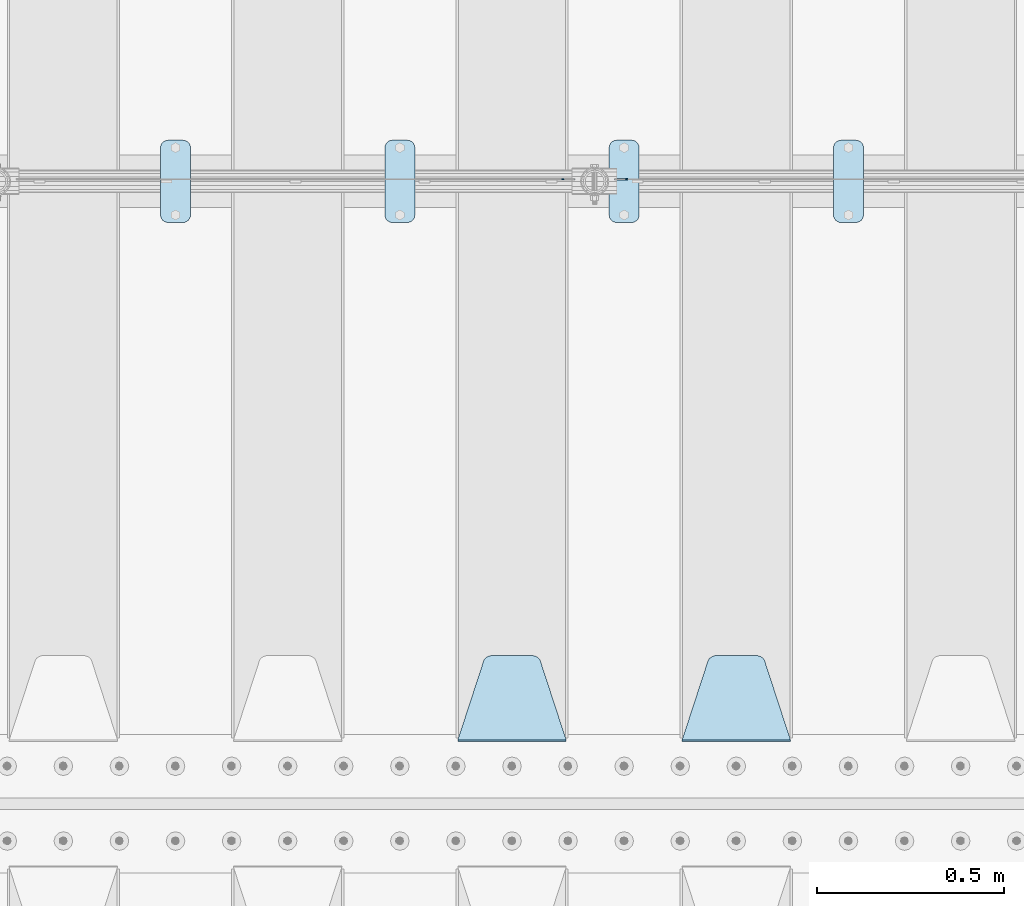
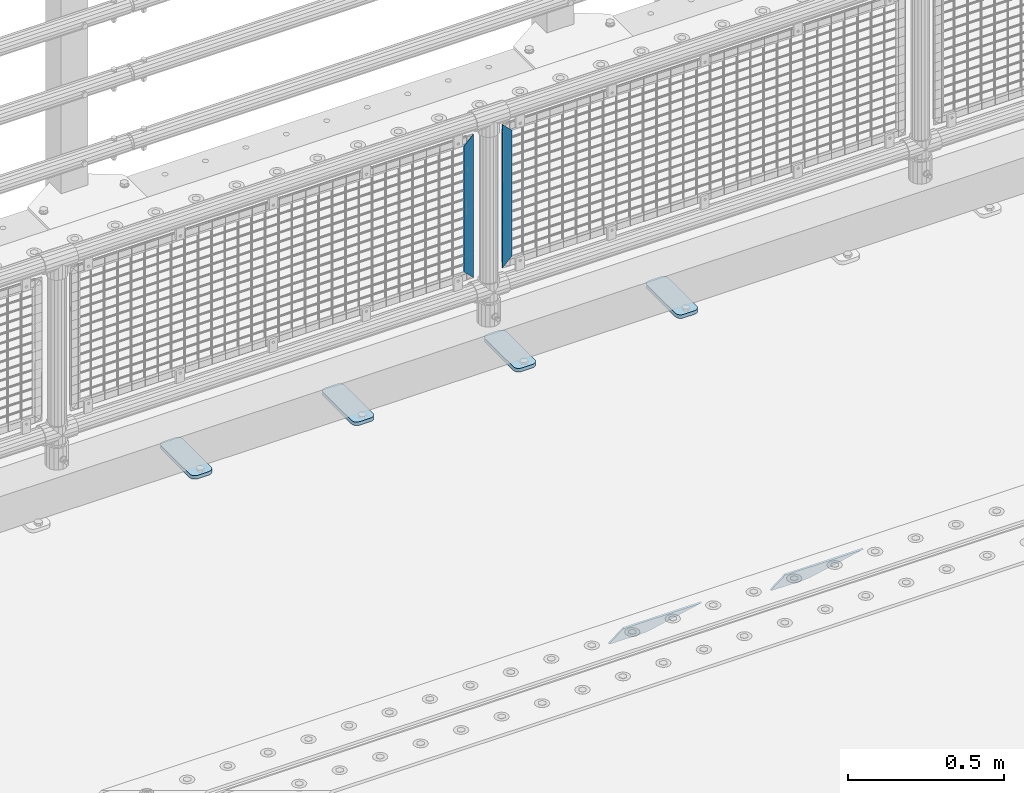
# One storey, part 182 of 208: 8 plates.
"""IFC2X3 building model written with IfcOpenShell, lengths in millimetres."""

from ifc_helpers import new_model, si_unit, frame, origin_with_axes, place, context, subcontext, project, spatial, faceted_brep, material, type_object, element, save


model = new_model("IFC2X3")

# Units and contexts
model_context = context("Model", 3, precision=1e-05, world=origin_with_axes())
body_context = subcontext(model_context, "Body", "Model", "MODEL_VIEW")
ifc_project = project(units=[si_unit("LENGTHUNIT", "METRE", prefix="MILLI"), si_unit("AREAUNIT", "SQUARE_METRE"), si_unit("VOLUMEUNIT", "CUBIC_METRE"), si_unit("MASSUNIT", "GRAM", prefix="KILO"), si_unit("TIMEUNIT", "SECOND"), si_unit("PLANEANGLEUNIT", "RADIAN"), si_unit("SOLIDANGLEUNIT", "STERADIAN"), si_unit("THERMODYNAMICTEMPERATUREUNIT", "DEGREE_CELSIUS"), si_unit("LUMINOUSINTENSITYUNIT", "LUMEN")], contexts=[model_context])

# Site, building, storey
site_placement = place(None, origin_with_axes())
site = spatial("IfcSite", under=ifc_project, at=site_placement, CompositionType="ELEMENT")
building_placement = place(site_placement, origin_with_axes())
building = spatial("IfcBuilding", under=site, at=building_placement, Name="Standard", CompositionType="ELEMENT")
storey_placement = place(building_placement, origin_with_axes())
storey = spatial("IfcBuildingStorey", under=building, at=storey_placement, Name="Undefined", CompositionType="ELEMENT", Elevation=0.0)

# Plates
ifc_material_1 = material(Name="STEEL/S355J2")
plate_type_1 = type_object("IfcPlateType", PredefinedType="NOTDEFINED")
plate_1_placement = place(storey_placement, frame((-31590.0, 4774.5, 21.0199999999977), z_axis=(1.0, 0.0, 0.0), x_axis=(0.0, -1.0, 0.0)))
element("IfcPlate", 1, at=plate_1_placement, inside=storey, type_object=plate_type_1, material=ifc_material_1, context=body_context, shape_type="Brep", body=[
    faceted_brep([(0.0, -7.0, 20.0), (0.0, -7.0, 60.0), (0.0, 7.0, 60.0), (0.0, 7.0, 20.0), (0.384294391935327, -7.0, 63.9018064403208), (0.384294391935327, 7.0, 63.9018064403208), (1.52240934977453, -7.0, 67.6536686473009), (1.52240934977453, 7.0, 67.6536686473009), (3.37060775394912, -7.0, 71.1114046603907), (3.37060775394912, 7.0, 71.1114046603907), (5.85786437626939, -7.0, 74.1421356237297), (5.85786437626939, 7.0, 74.1421356237297), (8.8885953396084, -7.0, 76.62939224605), (8.8885953396084, 7.0, 76.62939224605), (12.3463313526981, -7.0, 78.4775906502255), (12.3463313526981, 7.0, 78.4775906502255), (16.0981935596774, -7.0, 79.6157056080629), (16.0981935596774, 7.0, 79.6157056080629), (20.0, -7.0, 80.0), (20.0, 7.0, 80.0), (200.0, -7.0, 80.0), (200.0, 7.0, 80.0), (203.901806440323, -7.0, 79.6157056080629), (203.901806440323, 7.0, 79.6157056080629), (207.653668647302, -7.0, 78.4775906502255), (207.653668647302, 7.0, 78.4775906502255), (211.111404660393, -7.0, 76.62939224605), (211.111404660393, 7.0, 76.62939224605), (214.142135623731, -7.0, 74.1421356237297), (214.142135623731, 7.0, 74.1421356237297), (216.629392246051, -7.0, 71.1114046603907), (216.629392246051, 7.0, 71.1114046603907), (218.477590650225, -7.0, 67.6536686473009), (218.477590650225, 7.0, 67.6536686473009), (219.615705608065, -7.0, 63.9018064403208), (219.615705608065, 7.0, 63.9018064403208), (220.0, -7.0, 60.0), (220.0, 7.0, 60.0), (220.0, -7.0, 20.0), (220.0, 7.0, 20.0), (219.615705608065, -7.0, 16.0981935596792), (219.615705608065, 7.0, 16.0981935596792), (218.477590650225, -7.0, 12.3463313526991), (218.477590650225, 7.0, 12.3463313526991), (216.629392246051, -7.0, 8.88859533960931), (216.629392246051, 7.0, 8.88859533960931), (214.142135623731, -7.0, 5.8578643762703), (214.142135623731, 7.0, 5.8578643762703), (211.111404660393, -7.0, 3.37060775395003), (211.111404660393, 7.0, 3.37060775395003), (207.653668647302, -7.0, 1.52240934977453), (207.653668647302, 7.0, 1.52240934977453), (203.901806440323, -7.0, 0.384294391937146), (203.901806440323, 7.0, 0.384294391937146), (200.0, -7.0, 0.0), (200.0, 7.0, 0.0), (20.0, -7.0, 0.0), (20.0, 7.0, 0.0), (16.0981935596774, -7.0, 0.384294391937146), (16.0981935596774, 7.0, 0.384294391937146), (12.3463313526981, -7.0, 1.52240934977453), (12.3463313526981, 7.0, 1.52240934977453), (8.8885953396084, -7.0, 3.37060775395003), (8.8885953396084, 7.0, 3.37060775395003), (5.85786437626939, -7.0, 5.8578643762703), (5.85786437626939, 7.0, 5.8578643762703), (3.37060775394912, -7.0, 8.88859533960931), (3.37060775394912, 7.0, 8.88859533960931), (1.52240934977453, -7.0, 12.3463313526991), (1.52240934977453, 7.0, 12.3463313526991), (0.384294391935327, -7.0, 16.0981935596792), (0.384294391935327, 7.0, 16.0981935596792)], [[[0, 1, 2, 3]], [[1, 4, 5, 2]], [[4, 6, 7, 5]], [[6, 8, 9, 7]], [[8, 10, 11, 9]], [[10, 12, 13, 11]], [[12, 14, 15, 13]], [[14, 16, 17, 15]], [[16, 18, 19, 17]], [[18, 20, 21, 19]], [[20, 22, 23, 21]], [[22, 24, 25, 23]], [[24, 26, 27, 25]], [[26, 28, 29, 27]], [[28, 30, 31, 29]], [[30, 32, 33, 31]], [[32, 34, 35, 33]], [[34, 36, 37, 35]], [[36, 38, 39, 37]], [[38, 40, 41, 39]], [[40, 42, 43, 41]], [[42, 44, 45, 43]], [[44, 46, 47, 45]], [[46, 48, 49, 47]], [[48, 50, 51, 49]], [[50, 52, 53, 51]], [[52, 54, 55, 53]], [[54, 56, 57, 55]], [[56, 58, 59, 57]], [[58, 60, 61, 59]], [[60, 62, 63, 61]], [[62, 64, 65, 63]], [[64, 66, 67, 65]], [[66, 68, 69, 67]], [[68, 70, 71, 69]], [[70, 0, 3, 71]], [[5, 7, 9, 11, 13, 15, 17, 19, 21, 23, 25, 27, 29, 31, 33, 35, 37, 39, 41, 43, 45, 47, 49, 51, 53, 55, 57, 59, 61, 63, 65, 67, 69, 71, 3, 2]], [[70, 68, 66, 64, 62, 60, 58, 56, 54, 52, 50, 48, 46, 44, 42, 40, 38, 36, 34, 32, 30, 28, 26, 24, 22, 20, 18, 16, 14, 12, 10, 8, 6, 4, 1, 0]]]),
])
plate_2_placement = place(storey_placement, frame((-32190.0, 4774.5, 21.0199999999977), z_axis=(1.0, 0.0, 0.0), x_axis=(0.0, -1.0, 0.0)))
element("IfcPlate", 2, at=plate_2_placement, inside=storey, type_object=plate_type_1, material=ifc_material_1, context=body_context, shape_type="Brep", body=[
    faceted_brep([(0.0, -7.0, 20.0), (0.0, -7.0, 60.0), (0.0, 7.0, 60.0), (0.0, 7.0, 20.0), (0.384294391935327, -7.0, 63.9018064403208), (0.384294391935327, 7.0, 63.9018064403208), (1.52240934977453, -7.0, 67.6536686473009), (1.52240934977453, 7.0, 67.6536686473009), (3.37060775394912, -7.0, 71.1114046603907), (3.37060775394912, 7.0, 71.1114046603907), (5.85786437626939, -7.0, 74.1421356237297), (5.85786437626939, 7.0, 74.1421356237297), (8.8885953396084, -7.0, 76.62939224605), (8.8885953396084, 7.0, 76.62939224605), (12.3463313526981, -7.0, 78.4775906502255), (12.3463313526981, 7.0, 78.4775906502255), (16.0981935596774, -7.0, 79.6157056080629), (16.0981935596774, 7.0, 79.6157056080629), (20.0, -7.0, 80.0), (20.0, 7.0, 80.0), (200.0, -7.0, 80.0), (200.0, 7.0, 80.0), (203.901806440323, -7.0, 79.6157056080629), (203.901806440323, 7.0, 79.6157056080629), (207.653668647302, -7.0, 78.4775906502255), (207.653668647302, 7.0, 78.4775906502255), (211.111404660393, -7.0, 76.62939224605), (211.111404660393, 7.0, 76.62939224605), (214.142135623731, -7.0, 74.1421356237297), (214.142135623731, 7.0, 74.1421356237297), (216.629392246051, -7.0, 71.1114046603907), (216.629392246051, 7.0, 71.1114046603907), (218.477590650225, -7.0, 67.6536686473009), (218.477590650225, 7.0, 67.6536686473009), (219.615705608065, -7.0, 63.9018064403208), (219.615705608065, 7.0, 63.9018064403208), (220.0, -7.0, 60.0), (220.0, 7.0, 60.0), (220.0, -7.0, 20.0), (220.0, 7.0, 20.0), (219.615705608065, -7.0, 16.0981935596792), (219.615705608065, 7.0, 16.0981935596792), (218.477590650225, -7.0, 12.3463313526991), (218.477590650225, 7.0, 12.3463313526991), (216.629392246051, -7.0, 8.88859533960931), (216.629392246051, 7.0, 8.88859533960931), (214.142135623731, -7.0, 5.8578643762703), (214.142135623731, 7.0, 5.8578643762703), (211.111404660393, -7.0, 3.37060775395003), (211.111404660393, 7.0, 3.37060775395003), (207.653668647302, -7.0, 1.52240934977453), (207.653668647302, 7.0, 1.52240934977453), (203.901806440323, -7.0, 0.384294391937146), (203.901806440323, 7.0, 0.384294391937146), (200.0, -7.0, 0.0), (200.0, 7.0, 0.0), (20.0, -7.0, 0.0), (20.0, 7.0, 0.0), (16.0981935596774, -7.0, 0.384294391937146), (16.0981935596774, 7.0, 0.384294391937146), (12.3463313526981, -7.0, 1.52240934977453), (12.3463313526981, 7.0, 1.52240934977453), (8.8885953396084, -7.0, 3.37060775395003), (8.8885953396084, 7.0, 3.37060775395003), (5.85786437626939, -7.0, 5.8578643762703), (5.85786437626939, 7.0, 5.8578643762703), (3.37060775394912, -7.0, 8.88859533960931), (3.37060775394912, 7.0, 8.88859533960931), (1.52240934977453, -7.0, 12.3463313526991), (1.52240934977453, 7.0, 12.3463313526991), (0.384294391935327, -7.0, 16.0981935596792), (0.384294391935327, 7.0, 16.0981935596792)], [[[0, 1, 2, 3]], [[1, 4, 5, 2]], [[4, 6, 7, 5]], [[6, 8, 9, 7]], [[8, 10, 11, 9]], [[10, 12, 13, 11]], [[12, 14, 15, 13]], [[14, 16, 17, 15]], [[16, 18, 19, 17]], [[18, 20, 21, 19]], [[20, 22, 23, 21]], [[22, 24, 25, 23]], [[24, 26, 27, 25]], [[26, 28, 29, 27]], [[28, 30, 31, 29]], [[30, 32, 33, 31]], [[32, 34, 35, 33]], [[34, 36, 37, 35]], [[36, 38, 39, 37]], [[38, 40, 41, 39]], [[40, 42, 43, 41]], [[42, 44, 45, 43]], [[44, 46, 47, 45]], [[46, 48, 49, 47]], [[48, 50, 51, 49]], [[50, 52, 53, 51]], [[52, 54, 55, 53]], [[54, 56, 57, 55]], [[56, 58, 59, 57]], [[58, 60, 61, 59]], [[60, 62, 63, 61]], [[62, 64, 65, 63]], [[64, 66, 67, 65]], [[66, 68, 69, 67]], [[68, 70, 71, 69]], [[70, 0, 3, 71]], [[5, 7, 9, 11, 13, 15, 17, 19, 21, 23, 25, 27, 29, 31, 33, 35, 37, 39, 41, 43, 45, 47, 49, 51, 53, 55, 57, 59, 61, 63, 65, 67, 69, 71, 3, 2]], [[70, 68, 66, 64, 62, 60, 58, 56, 54, 52, 50, 48, 46, 44, 42, 40, 38, 36, 34, 32, 30, 28, 26, 24, 22, 20, 18, 16, 14, 12, 10, 8, 6, 4, 1, 0]]]),
])
plate_3_placement = place(storey_placement, frame((-32790.0, 4774.5, 21.0199999999977), z_axis=(1.0, 0.0, 0.0), x_axis=(0.0, -1.0, 0.0)))
element("IfcPlate", 3, at=plate_3_placement, inside=storey, type_object=plate_type_1, material=ifc_material_1, context=body_context, shape_type="Brep", body=[
    faceted_brep([(0.0, -7.0, 20.0), (0.0, -7.0, 60.0), (0.0, 7.0, 60.0), (0.0, 7.0, 20.0), (0.384294391935327, -7.0, 63.9018064403208), (0.384294391935327, 7.0, 63.9018064403208), (1.52240934977453, -7.0, 67.6536686473009), (1.52240934977453, 7.0, 67.6536686473009), (3.37060775394912, -7.0, 71.1114046603907), (3.37060775394912, 7.0, 71.1114046603907), (5.85786437626939, -7.0, 74.1421356237297), (5.85786437626939, 7.0, 74.1421356237297), (8.8885953396084, -7.0, 76.62939224605), (8.8885953396084, 7.0, 76.62939224605), (12.3463313526981, -7.0, 78.4775906502255), (12.3463313526981, 7.0, 78.4775906502255), (16.0981935596774, -7.0, 79.6157056080629), (16.0981935596774, 7.0, 79.6157056080629), (20.0, -7.0, 80.0), (20.0, 7.0, 80.0), (200.0, -7.0, 80.0), (200.0, 7.0, 80.0), (203.901806440323, -7.0, 79.6157056080629), (203.901806440323, 7.0, 79.6157056080629), (207.653668647302, -7.0, 78.4775906502255), (207.653668647302, 7.0, 78.4775906502255), (211.111404660393, -7.0, 76.62939224605), (211.111404660393, 7.0, 76.62939224605), (214.142135623731, -7.0, 74.1421356237297), (214.142135623731, 7.0, 74.1421356237297), (216.629392246051, -7.0, 71.1114046603907), (216.629392246051, 7.0, 71.1114046603907), (218.477590650225, -7.0, 67.6536686473009), (218.477590650225, 7.0, 67.6536686473009), (219.615705608065, -7.0, 63.9018064403208), (219.615705608065, 7.0, 63.9018064403208), (220.0, -7.0, 60.0), (220.0, 7.0, 60.0), (220.0, -7.0, 20.0), (220.0, 7.0, 20.0), (219.615705608065, -7.0, 16.0981935596792), (219.615705608065, 7.0, 16.0981935596792), (218.477590650225, -7.0, 12.3463313526991), (218.477590650225, 7.0, 12.3463313526991), (216.629392246051, -7.0, 8.88859533960931), (216.629392246051, 7.0, 8.88859533960931), (214.142135623731, -7.0, 5.8578643762703), (214.142135623731, 7.0, 5.8578643762703), (211.111404660393, -7.0, 3.37060775395003), (211.111404660393, 7.0, 3.37060775395003), (207.653668647302, -7.0, 1.52240934977453), (207.653668647302, 7.0, 1.52240934977453), (203.901806440323, -7.0, 0.384294391937146), (203.901806440323, 7.0, 0.384294391937146), (200.0, -7.0, 0.0), (200.0, 7.0, 0.0), (20.0, -7.0, 0.0), (20.0, 7.0, 0.0), (16.0981935596774, -7.0, 0.384294391937146), (16.0981935596774, 7.0, 0.384294391937146), (12.3463313526981, -7.0, 1.52240934977453), (12.3463313526981, 7.0, 1.52240934977453), (8.8885953396084, -7.0, 3.37060775395003), (8.8885953396084, 7.0, 3.37060775395003), (5.85786437626939, -7.0, 5.8578643762703), (5.85786437626939, 7.0, 5.8578643762703), (3.37060775394912, -7.0, 8.88859533960931), (3.37060775394912, 7.0, 8.88859533960931), (1.52240934977453, -7.0, 12.3463313526991), (1.52240934977453, 7.0, 12.3463313526991), (0.384294391935327, -7.0, 16.0981935596792), (0.384294391935327, 7.0, 16.0981935596792)], [[[0, 1, 2, 3]], [[1, 4, 5, 2]], [[4, 6, 7, 5]], [[6, 8, 9, 7]], [[8, 10, 11, 9]], [[10, 12, 13, 11]], [[12, 14, 15, 13]], [[14, 16, 17, 15]], [[16, 18, 19, 17]], [[18, 20, 21, 19]], [[20, 22, 23, 21]], [[22, 24, 25, 23]], [[24, 26, 27, 25]], [[26, 28, 29, 27]], [[28, 30, 31, 29]], [[30, 32, 33, 31]], [[32, 34, 35, 33]], [[34, 36, 37, 35]], [[36, 38, 39, 37]], [[38, 40, 41, 39]], [[40, 42, 43, 41]], [[42, 44, 45, 43]], [[44, 46, 47, 45]], [[46, 48, 49, 47]], [[48, 50, 51, 49]], [[50, 52, 53, 51]], [[52, 54, 55, 53]], [[54, 56, 57, 55]], [[56, 58, 59, 57]], [[58, 60, 61, 59]], [[60, 62, 63, 61]], [[62, 64, 65, 63]], [[64, 66, 67, 65]], [[66, 68, 69, 67]], [[68, 70, 71, 69]], [[70, 0, 3, 71]], [[5, 7, 9, 11, 13, 15, 17, 19, 21, 23, 25, 27, 29, 31, 33, 35, 37, 39, 41, 43, 45, 47, 49, 51, 53, 55, 57, 59, 61, 63, 65, 67, 69, 71, 3, 2]], [[70, 68, 66, 64, 62, 60, 58, 56, 54, 52, 50, 48, 46, 44, 42, 40, 38, 36, 34, 32, 30, 28, 26, 24, 22, 20, 18, 16, 14, 12, 10, 8, 6, 4, 1, 0]]]),
])
plate_4_placement = place(storey_placement, frame((-33390.0, 4774.5, 21.0199999999977), z_axis=(1.0, 0.0, 0.0), x_axis=(0.0, -1.0, 0.0)))
element("IfcPlate", 4, at=plate_4_placement, inside=storey, type_object=plate_type_1, material=ifc_material_1, context=body_context, shape_type="Brep", body=[
    faceted_brep([(0.0, -7.0, 20.0), (0.0, -7.0, 60.0), (0.0, 7.0, 60.0), (0.0, 7.0, 20.0), (0.384294391935327, -7.0, 63.9018064403208), (0.384294391935327, 7.0, 63.9018064403208), (1.52240934977453, -7.0, 67.6536686473009), (1.52240934977453, 7.0, 67.6536686473009), (3.37060775394912, -7.0, 71.1114046603907), (3.37060775394912, 7.0, 71.1114046603907), (5.85786437626939, -7.0, 74.1421356237297), (5.85786437626939, 7.0, 74.1421356237297), (8.8885953396084, -7.0, 76.62939224605), (8.8885953396084, 7.0, 76.62939224605), (12.3463313526981, -7.0, 78.4775906502255), (12.3463313526981, 7.0, 78.4775906502255), (16.0981935596774, -7.0, 79.6157056080629), (16.0981935596774, 7.0, 79.6157056080629), (20.0, -7.0, 80.0), (20.0, 7.0, 80.0), (200.0, -7.0, 80.0), (200.0, 7.0, 80.0), (203.901806440323, -7.0, 79.6157056080629), (203.901806440323, 7.0, 79.6157056080629), (207.653668647302, -7.0, 78.4775906502255), (207.653668647302, 7.0, 78.4775906502255), (211.111404660393, -7.0, 76.62939224605), (211.111404660393, 7.0, 76.62939224605), (214.142135623731, -7.0, 74.1421356237297), (214.142135623731, 7.0, 74.1421356237297), (216.629392246051, -7.0, 71.1114046603907), (216.629392246051, 7.0, 71.1114046603907), (218.477590650225, -7.0, 67.6536686473009), (218.477590650225, 7.0, 67.6536686473009), (219.615705608065, -7.0, 63.9018064403208), (219.615705608065, 7.0, 63.9018064403208), (220.0, -7.0, 60.0), (220.0, 7.0, 60.0), (220.0, -7.0, 20.0), (220.0, 7.0, 20.0), (219.615705608065, -7.0, 16.0981935596792), (219.615705608065, 7.0, 16.0981935596792), (218.477590650225, -7.0, 12.3463313526991), (218.477590650225, 7.0, 12.3463313526991), (216.629392246051, -7.0, 8.88859533960931), (216.629392246051, 7.0, 8.88859533960931), (214.142135623731, -7.0, 5.8578643762703), (214.142135623731, 7.0, 5.8578643762703), (211.111404660393, -7.0, 3.37060775395003), (211.111404660393, 7.0, 3.37060775395003), (207.653668647302, -7.0, 1.52240934977453), (207.653668647302, 7.0, 1.52240934977453), (203.901806440323, -7.0, 0.384294391937146), (203.901806440323, 7.0, 0.384294391937146), (200.0, -7.0, 0.0), (200.0, 7.0, 0.0), (20.0, -7.0, 0.0), (20.0, 7.0, 0.0), (16.0981935596774, -7.0, 0.384294391937146), (16.0981935596774, 7.0, 0.384294391937146), (12.3463313526981, -7.0, 1.52240934977453), (12.3463313526981, 7.0, 1.52240934977453), (8.8885953396084, -7.0, 3.37060775395003), (8.8885953396084, 7.0, 3.37060775395003), (5.85786437626939, -7.0, 5.8578643762703), (5.85786437626939, 7.0, 5.8578643762703), (3.37060775394912, -7.0, 8.88859533960931), (3.37060775394912, 7.0, 8.88859533960931), (1.52240934977453, -7.0, 12.3463313526991), (1.52240934977453, 7.0, 12.3463313526991), (0.384294391935327, -7.0, 16.0981935596792), (0.384294391935327, 7.0, 16.0981935596792)], [[[0, 1, 2, 3]], [[1, 4, 5, 2]], [[4, 6, 7, 5]], [[6, 8, 9, 7]], [[8, 10, 11, 9]], [[10, 12, 13, 11]], [[12, 14, 15, 13]], [[14, 16, 17, 15]], [[16, 18, 19, 17]], [[18, 20, 21, 19]], [[20, 22, 23, 21]], [[22, 24, 25, 23]], [[24, 26, 27, 25]], [[26, 28, 29, 27]], [[28, 30, 31, 29]], [[30, 32, 33, 31]], [[32, 34, 35, 33]], [[34, 36, 37, 35]], [[36, 38, 39, 37]], [[38, 40, 41, 39]], [[40, 42, 43, 41]], [[42, 44, 45, 43]], [[44, 46, 47, 45]], [[46, 48, 49, 47]], [[48, 50, 51, 49]], [[50, 52, 53, 51]], [[52, 54, 55, 53]], [[54, 56, 57, 55]], [[56, 58, 59, 57]], [[58, 60, 61, 59]], [[60, 62, 63, 61]], [[62, 64, 65, 63]], [[64, 66, 67, 65]], [[66, 68, 69, 67]], [[68, 70, 71, 69]], [[70, 0, 3, 71]], [[5, 7, 9, 11, 13, 15, 17, 19, 21, 23, 25, 27, 29, 31, 33, 35, 37, 39, 41, 43, 45, 47, 49, 51, 53, 55, 57, 59, 61, 63, 65, 67, 69, 71, 3, 2]], [[70, 68, 66, 64, 62, 60, 58, 56, 54, 52, 50, 48, 46, 44, 42, 40, 38, 36, 34, 32, 30, 28, 26, 24, 22, 20, 18, 16, 14, 12, 10, 8, 6, 4, 1, 0]]]),
])
ifc_material_2 = material(Name="STEEL/S355N")
plate_type_2 = type_object("IfcPlateType", PredefinedType="NOTDEFINED")
plate_5_placement = place(storey_placement, frame((-31705.0, 3168.23223304702, -1.76776695296758), z_axis=(0.0, 0.707106781186547, -0.707106781186548), x_axis=(-1.0, 0.0, 0.0)))
element("IfcPlate", 5, at=plate_5_placement, inside=storey, type_object=plate_type_2, material=ifc_material_2, context=body_context, shape_type="Brep", body=[
    faceted_brep([(0.0, -2.5, 0.0), (69.345504679477, -2.5, 300.17173142483), (69.345504679477, 2.5, 300.17173142483), (0.0, 2.5, 0.0), (70.9274061199576, -2.5, 304.897442415399), (70.9274061199576, 2.5, 304.8974424154), (73.3818627772307, -2.5, 309.234538108527), (73.3818627772307, 2.5, 309.234538108527), (76.6187032999551, -2.5, 313.023683126103), (76.6187032999551, 2.5, 313.023683126103), (80.5190132704993, -2.5, 316.125672595371), (80.5190132704993, 2.5, 316.125672595371), (84.9395038596849, -2.5, 318.426546230476), (84.9395038596849, 2.50000000000091, 318.426546230476), (89.7177759439219, -2.5, 319.841774983275), (89.7177759439219, 2.50000000000091, 319.841774983275), (94.678286292652, -2.49999999999909, 320.319366455078), (94.678286292652, 2.5, 320.319366455078), (195.321713707348, -2.49999999999909, 320.319366455078), (195.321713707348, 2.5, 320.319366455078), (200.282224056078, -2.5, 319.841774983275), (200.282224056078, 2.5, 319.841774983274), (205.060496140315, -2.5, 318.426546230475), (205.060496140315, 2.5, 318.426546230475), (209.480986729501, -2.5, 316.125672595371), (209.480986729501, 2.50000000000091, 316.125672595371), (213.381296700045, -2.5, 313.023683126102), (213.381296700045, 2.5, 313.023683126102), (216.618137222769, -2.5, 309.234538108526), (216.618137222769, 2.5, 309.234538108527), (219.072593880042, -2.5, 304.897442415399), (219.072593880042, 2.5, 304.897442415399), (220.654495320523, -2.5, 300.17173142483), (220.654495320523, 2.5, 300.17173142483), (290.0, -2.5, 0.0), (290.0, 2.5, 0.0)], [[[0, 1, 2, 3]], [[1, 4, 5, 2]], [[4, 6, 7, 5]], [[6, 8, 9, 7]], [[8, 10, 11, 9]], [[10, 12, 13, 11]], [[12, 14, 15, 13]], [[14, 16, 17, 15]], [[16, 18, 19, 17]], [[18, 20, 21, 19]], [[20, 22, 23, 21]], [[22, 24, 25, 23]], [[24, 26, 27, 25]], [[26, 28, 29, 27]], [[28, 30, 31, 29]], [[30, 32, 33, 31]], [[32, 34, 35, 33]], [[34, 0, 3, 35]], [[5, 7, 9, 11, 13, 15, 17, 19, 21, 23, 25, 27, 29, 31, 33, 35, 3, 2]], [[34, 32, 30, 28, 26, 24, 22, 20, 18, 16, 14, 12, 10, 8, 6, 4, 1, 0]]]),
])
plate_6_placement = place(storey_placement, frame((-32305.0, 3168.23223304702, -1.76776695296758), z_axis=(0.0, 0.707106781186547, -0.707106781186548), x_axis=(-1.0, 0.0, 0.0)))
element("IfcPlate", 6, at=plate_6_placement, inside=storey, type_object=plate_type_2, material=ifc_material_2, context=body_context, shape_type="Brep", body=[
    faceted_brep([(0.0, -2.5, 0.0), (69.345504679477, -2.5, 300.17173142483), (69.345504679477, 2.5, 300.17173142483), (0.0, 2.5, 0.0), (70.9274061199576, -2.5, 304.897442415399), (70.9274061199576, 2.5, 304.8974424154), (73.3818627772307, -2.5, 309.234538108527), (73.3818627772307, 2.5, 309.234538108527), (76.6187032999551, -2.5, 313.023683126103), (76.6187032999551, 2.5, 313.023683126103), (80.5190132704993, -2.5, 316.125672595371), (80.5190132704993, 2.5, 316.125672595371), (84.9395038596849, -2.5, 318.426546230476), (84.9395038596849, 2.50000000000091, 318.426546230476), (89.7177759439219, -2.5, 319.841774983275), (89.7177759439219, 2.50000000000091, 319.841774983275), (94.678286292652, -2.49999999999909, 320.319366455078), (94.678286292652, 2.5, 320.319366455078), (195.321713707348, -2.49999999999909, 320.319366455078), (195.321713707348, 2.5, 320.319366455078), (200.282224056078, -2.5, 319.841774983275), (200.282224056078, 2.5, 319.841774983274), (205.060496140315, -2.5, 318.426546230475), (205.060496140315, 2.5, 318.426546230475), (209.480986729501, -2.5, 316.125672595371), (209.480986729501, 2.50000000000091, 316.125672595371), (213.381296700045, -2.5, 313.023683126102), (213.381296700045, 2.5, 313.023683126102), (216.618137222769, -2.5, 309.234538108526), (216.618137222769, 2.5, 309.234538108527), (219.072593880042, -2.5, 304.897442415399), (219.072593880042, 2.5, 304.897442415399), (220.654495320523, -2.5, 300.17173142483), (220.654495320523, 2.5, 300.17173142483), (290.0, -2.5, 0.0), (290.0, 2.5, 0.0)], [[[0, 1, 2, 3]], [[1, 4, 5, 2]], [[4, 6, 7, 5]], [[6, 8, 9, 7]], [[8, 10, 11, 9]], [[10, 12, 13, 11]], [[12, 14, 15, 13]], [[14, 16, 17, 15]], [[16, 18, 19, 17]], [[18, 20, 21, 19]], [[20, 22, 23, 21]], [[22, 24, 25, 23]], [[24, 26, 27, 25]], [[26, 28, 29, 27]], [[28, 30, 31, 29]], [[30, 32, 33, 31]], [[32, 34, 35, 33]], [[34, 0, 3, 35]], [[5, 7, 9, 11, 13, 15, 17, 19, 21, 23, 25, 27, 29, 31, 33, 35, 3, 2]], [[34, 32, 30, 28, 26, 24, 22, 20, 18, 16, 14, 12, 10, 8, 6, 4, 1, 0]]]),
])
ifc_material_3 = material(Name="Misc_Undefined")
plate_type_3 = type_object("IfcPlateType", PredefinedType="NOTDEFINED")
plate_7_placement = place(storey_placement, frame((-32140.490286459, 4670.5, 879.519963133601), z_axis=(-0.707008801899319, 0.0, -0.707204746899291), x_axis=(-0.70720474689929, 0.0, 0.707008801899319)))
element("IfcPlate", 7, at=plate_7_placement, inside=storey, type_object=plate_type_3, material=ifc_material_3, context=body_context, shape_type="Brep", body=[
    faceted_brep([(0.0, -1.49999999999909, 3.63797880709171e-12), (-348.55218505859, -1.5, 348.655029296875), (-348.55218505859, 1.5, 348.655029296875), (0.0, 1.50000000000182, 3.63797880709171e-12), (-348.544891357418, -1.5, 398.152496337894), (-348.544891357418, 1.5, 398.152496337894), (49.5043945312536, -1.5, 7.6397554948926e-11), (49.5043945312536, 1.5, 7.6397554948926e-11)], [[[0, 1, 2, 3]], [[1, 4, 5, 2]], [[4, 6, 7, 5]], [[6, 0, 3, 7]], [[5, 7, 3, 2]], [[6, 4, 1, 0]]]),
])
plate_8_placement = place(storey_placement, frame((-32317.5003125164, 4670.5, 879.52), z_axis=(0.707103624179499, 0.0, -0.707109938179501), x_axis=(0.707109938179495, 0.0, 0.707103624179505)))
element("IfcPlate", 8, at=plate_8_placement, inside=storey, type_object=plate_type_3, material=ifc_material_3, context=body_context, shape_type="Brep", body=[
    faceted_brep([(0.0, -1.49999999999909, 3.63797880709171e-12), (-348.605163574219, -1.5, 348.602081298821), (-348.605163574219, 1.5, 348.602081298821), (0.0, 1.50000000000182, 3.63797880709171e-12), (-348.605163574219, -1.5, 398.099334716793), (-348.605163574219, 1.5, 398.099334716793), (49.4976959228516, -1.5, 6.91215973347425e-11), (49.4976959228516, 1.5, 6.91215973347425e-11)], [[[0, 1, 2, 3]], [[1, 4, 5, 2]], [[4, 6, 7, 5]], [[6, 0, 3, 7]], [[5, 7, 3, 2]], [[6, 4, 1, 0]]]),
])

save(model, "model.ifc")
